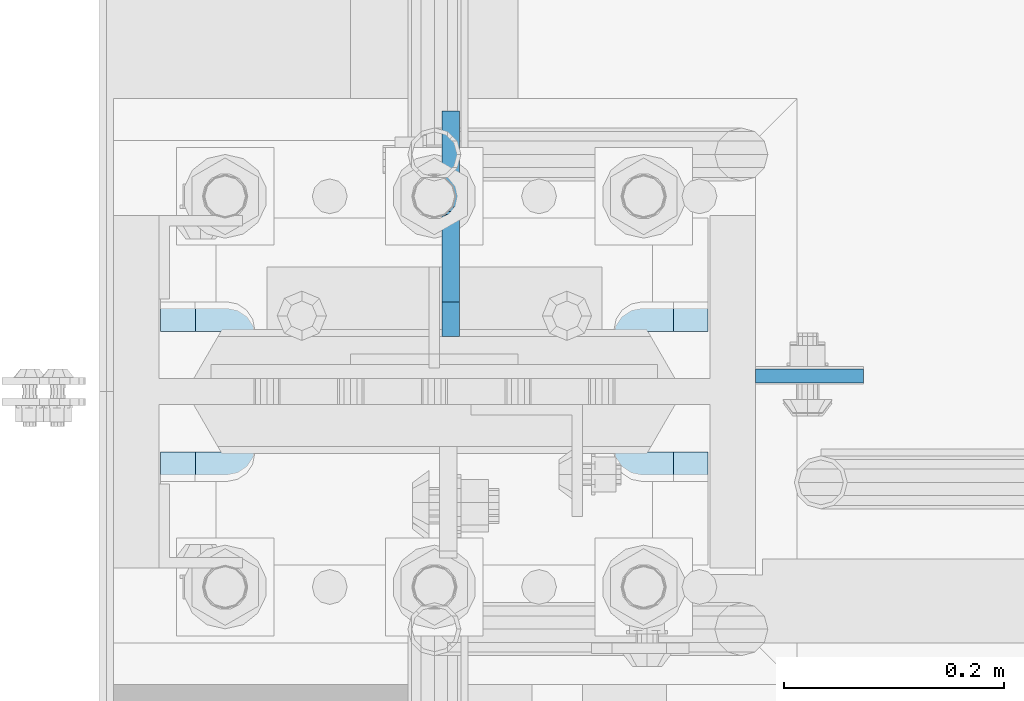
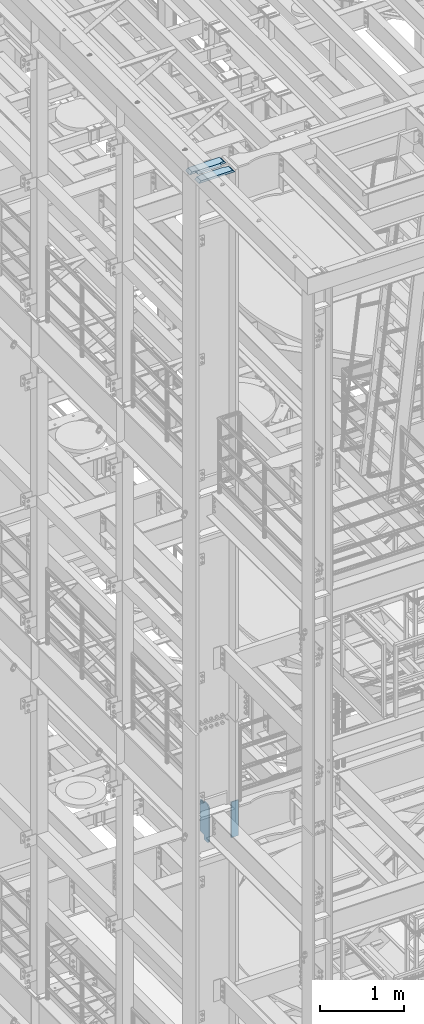
# One storey, part 1464 of 1876: 4 plates, 2 elements without a shape of their own.
"""IFC2X3 building model written with IfcOpenShell, lengths in millimetres."""

from ifc_helpers import new_model, si_unit, frame, origin_with_axes, place, context, subcontext, project, spatial, faceted_brep, material, type_object, element, aggregate, save


model = new_model("IFC2X3")

# Units and contexts
model_context = context("Model", 3, precision=1e-05, world=origin_with_axes())
body_context = subcontext(model_context, "Body", "Model", "MODEL_VIEW")
ifc_project = project(units=[si_unit("LENGTHUNIT", "METRE", prefix="MILLI"), si_unit("AREAUNIT", "SQUARE_METRE"), si_unit("VOLUMEUNIT", "CUBIC_METRE"), si_unit("MASSUNIT", "GRAM", prefix="KILO"), si_unit("TIMEUNIT", "SECOND"), si_unit("PLANEANGLEUNIT", "RADIAN"), si_unit("SOLIDANGLEUNIT", "STERADIAN"), si_unit("THERMODYNAMICTEMPERATUREUNIT", "DEGREE_CELSIUS"), si_unit("LUMINOUSINTENSITYUNIT", "LUMEN")], contexts=[model_context])

# Site, building, storey
site_placement = place(None, origin_with_axes())
site = spatial("IfcSite", under=ifc_project, at=site_placement, CompositionType="ELEMENT")
building_placement = place(site_placement, origin_with_axes())
building = spatial("IfcBuilding", under=site, at=building_placement, Name="Undefined", CompositionType="ELEMENT")
storey_placement = place(building_placement, origin_with_axes())
storey = spatial("IfcBuildingStorey", under=building, at=storey_placement, Name="Undefined", CompositionType="ELEMENT", Elevation=0.0)

# Assembly, plates
assembly_1_placement = place(storey_placement, origin_with_axes())
assembly_1 = element("IfcElementAssembly", 1, at=assembly_1_placement, inside=storey, Name="COLUMN", AssemblyPlace="NOTDEFINED", PredefinedType="RIGID_FRAME")
ifc_material_1 = material(Name="STEEL/A572-50")
plate_type_1 = type_object("IfcPlateType", PredefinedType="NOTDEFINED")
plate_1_placement = place(assembly_1_placement, frame((292.1, -4557.71300020218, 13254.0375), z_axis=(1.0, 0.0, 0.0), x_axis=(0.0, 0.0, -1.0)))
plate_1 = element("IfcPlate", 2, at=plate_1_placement, type_object=plate_type_1, material=ifc_material_1, Name="PLATE", context=body_context, shape_type="Brep", body=[
    faceted_brep([(0.0, -6.35000000000036, 0.0), (0.0, -6.34999999999991, 98.4250030517578), (0.0, 6.34999999999991, 98.4250030517578), (0.0, 6.35000000000036, 0.0), (517.525024414062, -6.35000000000036, 98.4250030517578), (517.525024414062, 6.35000000000036, 98.4250030517578), (517.525024414062, -6.35000000000036, 0.0), (517.525024414062, 6.35000000000036, 0.0)], [[[0, 1, 2, 3]], [[1, 4, 5, 2]], [[4, 6, 7, 5]], [[6, 0, 3, 7]], [[5, 7, 3, 2]], [[6, 4, 1, 0]]]),
])
ifc_material_2 = material(Name="STEEL/A36")
plate_type_2 = type_object("IfcPlateType", PredefinedType="NOTDEFINED")
plate_2_placement = place(assembly_1_placement, frame((15.080500125885, -4521.99375, 13271.5), z_axis=(0.0, 1.0, 0.0), x_axis=(0.0, 0.0, -1.0)))
plate_2 = element("IfcPlate", 3, at=plate_2_placement, type_object=plate_type_2, material=ifc_material_2, Name="PLATE", context=body_context, shape_type="Brep", body=[
    faceted_brep([(482.600012207031, -7.9375, 205.581252647308), (482.600012207031, -7.9375, 123.031246757508), (482.600012207031, 7.9375, 123.031246757508), (482.600012207031, 7.9375, 205.581253051758), (483.566742129618, -7.9375, 118.171167239462), (483.566742129618, 7.9375, 118.171167239462), (486.319756030096, -7.9375, 114.050990771309), (486.319756030096, 7.9375, 114.050990771309), (490.43993249825, -7.9375, 111.29797687083), (490.43993249825, 7.9375, 111.29797687083), (495.300012016296, -7.9375, 110.331246948243), (495.300012016296, 7.9375, 110.331246948243), (552.450012207031, -7.9375, 110.331246948243), (552.450012207031, 7.9375, 110.331246948243), (25.3999996185303, -7.9375, 205.581249999999), (25.3999996185303, 7.9375, 205.581253051758), (25.3999996185303, 7.9375, 123.031249809264), (25.3999996185303, -7.9375, 123.031249809264), (24.4332696959427, 7.9375, 118.171170291219), (24.4332696959427, -7.9375, 118.171170291219), (21.6802557954652, 7.9375, 114.050993823065), (21.6802557954652, -7.9375, 114.050993823065), (17.5600793273115, 7.9375, 111.297979922587), (17.5600793273115, -7.9375, 111.297979922587), (12.6999998092651, 7.9375, 110.331249999999), (12.6999998092651, -7.9375, 110.331249999999), (0.0, 7.9375, 110.33125), (0.0, -7.9375, 110.33125), (0.0, 7.93749999999999, 31.75), (0.0, -7.93749999999998, 31.75), (31.75, -7.93749999999998, 0.0), (31.75, 7.93749999999999, 0.0), (520.700012207031, -7.9375, 0.0), (520.700012207031, 7.9375, 0.0), (552.450012207031, -7.9375, 31.75), (552.450012207031, 7.9375, 31.75)], [[[0, 1, 2, 3]], [[4, 5, 2, 1]], [[6, 7, 5, 4]], [[8, 9, 7, 6]], [[10, 11, 9, 8]], [[12, 13, 11, 10]], [[14, 15, 16, 17]], [[17, 16, 18, 19]], [[19, 18, 20, 21]], [[21, 20, 22, 23]], [[23, 22, 24, 25]], [[25, 24, 26, 27]], [[28, 29, 27, 26]], [[30, 29, 28, 31]], [[32, 30, 31, 33]], [[34, 32, 33, 35]], [[8, 6, 4, 1, 0, 14, 17, 19, 21, 23, 25, 27, 29, 30, 32, 34, 12, 10]], [[15, 14, 0, 3]], [[35, 33, 31, 28, 26, 24, 22, 20, 18, 16, 15, 3, 2, 5, 7, 9, 11, 13]], [[34, 35, 13, 12]]]),
])
aggregate(assembly_1, [plate_2, plate_1])

assembly_2_placement = place(storey_placement, origin_with_axes())
assembly_2 = element("IfcElementAssembly", 4, at=assembly_2_placement, inside=storey, Name="COLUMN", AssemblyPlace="NOTDEFINED", PredefinedType="RIGID_FRAME")
plate_type_3 = type_object("IfcPlateType", PredefinedType="NOTDEFINED")
plate_3_placement = place(assembly_2_placement, frame((-249.2375, -4560.09375, 22539.325), z_axis=(1.0, 0.0, 0.0), x_axis=(0.0, 1.0, 0.0)))
plate_3 = element("IfcPlate", 5, at=plate_3_placement, type_object=plate_type_3, material=ifc_material_1, Name="PLATE", context=body_context, shape_type="Brep", body=[
    faceted_brep([(35.0225766570229, -15.875, 84.7582685515335), (35.0225766570229, 15.875, 84.7582685515335), (39.1427531251766, 15.875, 82.0052546510551), (39.1427531251766, -15.875, 82.0052546510551), (41.895767025655, 15.875, 77.8850781829015), (41.895767025655, -15.875, 77.8850781829015), (42.8624969482426, 15.875, 73.024998664856), (42.8624969482426, -15.875, 73.024998664856), (42.8624969482426, 15.875, 31.7500061035162), (42.8624969482426, -15.875, 0.0), (146.050003051758, 15.875, 31.7500061035162), (146.049995422363, -15.875, 0.0), (146.050003051758, 15.875, 466.725012207031), (146.050003051758, -15.875, 498.475012207031), (42.8624969482426, 15.875, 466.725012207031), (42.8624969482426, -15.875, 498.475), (42.8624969482426, 15.875, 425.450001335144), (42.8624969482426, -15.875, 425.450001335144), (41.895767025655, 15.875, 420.589921817099), (41.895767025655, -15.875, 420.589921817099), (39.1427531251766, 15.875, 416.469745348945), (39.1427531251766, -15.875, 416.469745348945), (35.0225766570229, 15.875, 413.716731448467), (35.0225766570229, -15.875, 413.716731448467), (30.1624971389774, -15.875, 412.750001525879), (31.7500000000036, 15.875, 413.065775478188), (30.1624971389774, 14.2874971389756, 412.750001525879), (0.0, -15.875, 412.750007629395), (30.1624971389774, -15.875, 85.7249984741211), (0.0, -15.875, 85.7249984741211), (30.1624971389774, 14.2874971389756, 85.7249984741211), (31.7500000000036, 15.875, 85.4092245218126)], [[[0, 1, 2, 3]], [[3, 2, 4, 5]], [[5, 4, 6, 7]], [[7, 6, 8, 9]], [[10, 11, 9, 8]], [[11, 10, 12, 13]], [[13, 12, 14, 15]], [[16, 17, 15, 14]], [[17, 16, 18, 19]], [[19, 18, 20, 21]], [[21, 20, 22, 23]], [[24, 23, 22, 25, 26]], [[24, 26, 27]], [[28, 0, 3, 5, 7, 9, 11, 13, 15, 17, 19, 21, 23, 24, 27, 29]], [[28, 29, 30]], [[1, 0, 28, 30, 31]], [[22, 20, 18, 16, 14, 12, 10, 8, 6, 4, 2, 1, 31, 25]], [[30, 29, 27, 26, 25, 31]]]),
])
plate_4_placement = place(assembly_2_placement, frame((-249.237506103516, -4729.95625, 22539.325), z_axis=(1.0, 0.0, 0.0), x_axis=(0.0, 1.0, 0.0)))
plate_4 = element("IfcPlate", 6, at=plate_4_placement, type_object=plate_type_3, material=ifc_material_1, Name="PLATE", context=body_context, shape_type="Brep", body=[
    faceted_brep([(106.907246874825, -15.875, 82.0052546510551), (106.907246874825, 15.875, 82.0052546510551), (111.027423342978, 15.875, 84.7582685515335), (111.027423342978, -15.875, 84.7582685515335), (104.154232974346, -15.875, 77.8850781829015), (104.154232974346, 15.875, 77.8850781829015), (103.187503051759, -15.875, 73.024998664856), (103.187503051759, 15.875, 73.024998664856), (103.187503051759, -15.875, 0.0), (103.187503051759, 15.875, 31.7500061035153), (0.0, -15.875, 0.0), (0.0, 15.875, 31.75), (0.0, -15.875, 498.475006103516), (0.0, 15.875, 466.725006103516), (103.187503051759, -15.875, 498.475012207031), (103.187503051759, 15.875, 466.725012207031), (103.187503051759, -15.875, 425.450001335144), (103.187503051759, 15.875, 425.450001335144), (104.154232974346, -15.875, 420.589921817099), (104.154232974346, 15.875, 420.589921817099), (106.907246874825, -15.875, 416.469745348945), (106.907246874825, 15.875, 416.469745348945), (111.027423342978, -15.875, 413.716731448467), (111.027423342978, 15.875, 413.716731448467), (115.887502861024, -15.875, 412.750001525879), (146.050002288819, -15.875, 412.750001525879), (115.887502861024, 14.2875000396052, 412.750001525879), (114.300003053293, 15.875, 413.06577487085), (114.300003053293, 15.875, 85.4092251291504), (115.887502861024, -15.875, 85.7249984741211), (115.887502861024, 14.2875000396052, 85.7249984741211), (146.050002288819, -15.875, 85.7249984741211)], [[[0, 1, 2, 3]], [[4, 5, 1, 0]], [[6, 7, 5, 4]], [[7, 6, 8, 9]], [[9, 8, 10, 11]], [[11, 10, 12, 13]], [[14, 15, 13, 12]], [[16, 17, 15, 14]], [[18, 19, 17, 16]], [[20, 21, 19, 18]], [[22, 23, 21, 20]], [[24, 25, 26]], [[23, 22, 24, 26, 27]], [[2, 1, 5, 7, 9, 11, 13, 15, 17, 19, 21, 23, 27, 28]], [[29, 3, 2, 28, 30]], [[29, 30, 31]], [[24, 22, 20, 18, 16, 14, 12, 10, 8, 6, 4, 0, 3, 29, 31, 25]], [[30, 28, 27, 26, 25, 31]]]),
])
aggregate(assembly_2, [plate_3, plate_4])

save(model, "model.ifc")
